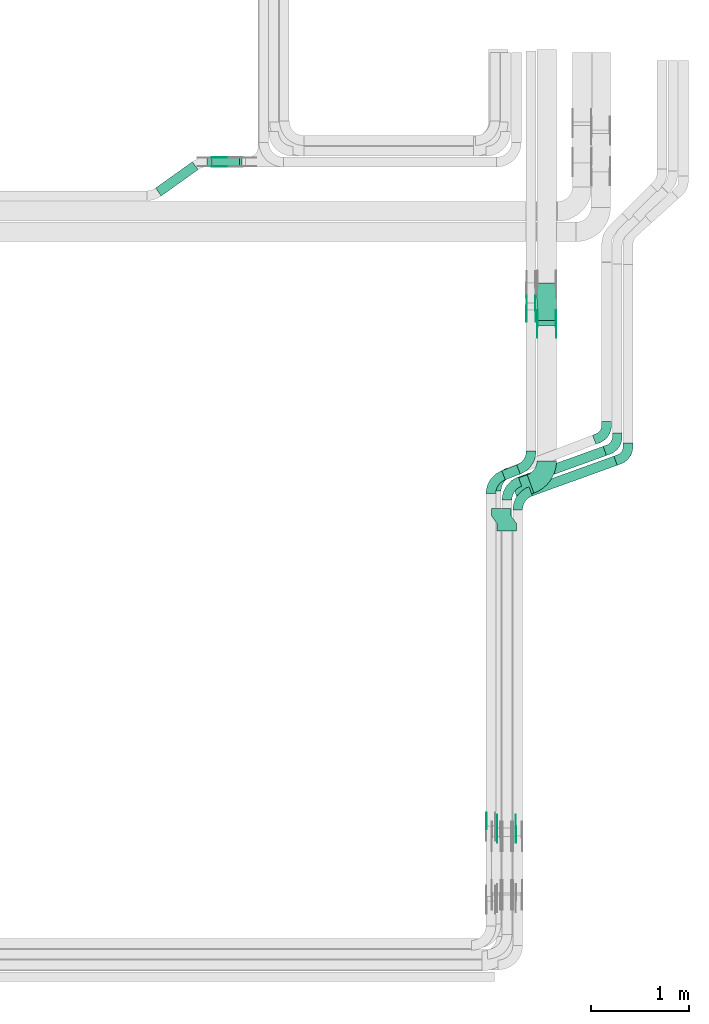
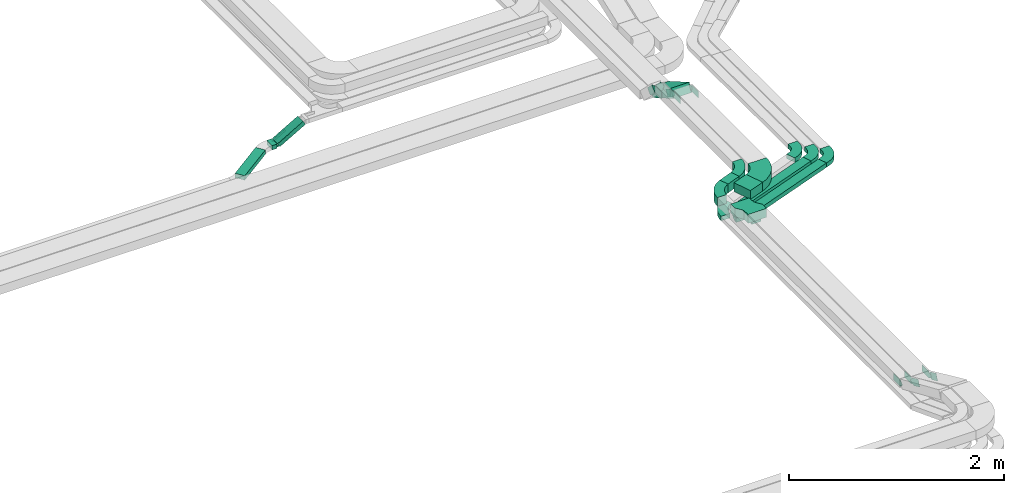
# One storey, part 19 of 23: 25 flow fittings, 8 flow segments.
"""IFC2X3 building model written with IfcOpenShell, lengths in millimetres."""

from ifc_helpers import new_model, entity, si_unit, converted_unit, derived_unit, direction, frame, frame_2d, origin, origin_2d_with_axis, place, context, subcontext, project, spatial, polyline, circle_curve, parameter, trimmed, segment, composite_curve, rectangle, outline, extrude, source, transform, mapped, material, type_object, type_shapes, element, save


model = new_model("IFC2X3")

# Units and contexts
model_context = context("Model", 3, precision=0.01, world=origin(), true_north=direction((6.12303176911189e-17, 1.0)))
body_context = subcontext(model_context, "Body", "Model", "MODEL_VIEW")
ifc_project = project(units=[si_unit("LENGTHUNIT", "METRE", prefix="MILLI"), si_unit("AREAUNIT", "SQUARE_METRE"), si_unit("VOLUMEUNIT", "CUBIC_METRE"), converted_unit("PLANEANGLEUNIT", "DEGREE", entity("IfcRatioMeasure", 0.0174532925199433), si_unit("PLANEANGLEUNIT", "RADIAN"), dimensions=[0, 0, 0, 0, 0, 0, 0]), si_unit("MASSUNIT", "GRAM", prefix="KILO"), derived_unit("MASSDENSITYUNIT", [(si_unit("MASSUNIT", "GRAM", prefix="KILO"), 1), (si_unit("LENGTHUNIT", "METRE"), -3)]), derived_unit("MOMENTOFINERTIAUNIT", [(si_unit("LENGTHUNIT", "METRE"), 4)]), si_unit("TIMEUNIT", "SECOND"), si_unit("FREQUENCYUNIT", "HERTZ"), si_unit("THERMODYNAMICTEMPERATUREUNIT", "DEGREE_CELSIUS"), derived_unit("THERMALTRANSMITTANCEUNIT", [(si_unit("MASSUNIT", "GRAM", prefix="KILO"), 1), (si_unit("THERMODYNAMICTEMPERATUREUNIT", "KELVIN"), -1), (si_unit("TIMEUNIT", "SECOND"), -3)]), derived_unit("VOLUMETRICFLOWRATEUNIT", [(si_unit("LENGTHUNIT", "METRE"), 3), (si_unit("TIMEUNIT", "SECOND"), -1)]), derived_unit("MASSFLOWRATEUNIT", [(si_unit("MASSUNIT", "GRAM", prefix="KILO"), 1), (si_unit("TIMEUNIT", "SECOND"), -1)]), derived_unit("ROTATIONALFREQUENCYUNIT", [(si_unit("TIMEUNIT", "SECOND"), -1)]), si_unit("ELECTRICCURRENTUNIT", "AMPERE"), si_unit("ELECTRICVOLTAGEUNIT", "VOLT"), si_unit("POWERUNIT", "WATT"), si_unit("FORCEUNIT", "NEWTON", prefix="KILO"), si_unit("ILLUMINANCEUNIT", "LUX"), si_unit("LUMINOUSFLUXUNIT", "LUMEN"), si_unit("LUMINOUSINTENSITYUNIT", "CANDELA"), derived_unit("USERDEFINED", [(si_unit("MASSUNIT", "GRAM", prefix="KILO"), -1), (si_unit("LENGTHUNIT", "METRE"), -2), (si_unit("TIMEUNIT", "SECOND"), 3), (si_unit("LUMINOUSFLUXUNIT", "LUMEN"), 1)]), derived_unit("LINEARVELOCITYUNIT", [(si_unit("LENGTHUNIT", "METRE"), 1), (si_unit("TIMEUNIT", "SECOND"), -1)]), si_unit("PRESSUREUNIT", "PASCAL"), derived_unit("USERDEFINED", [(si_unit("LENGTHUNIT", "METRE"), -2), (si_unit("MASSUNIT", "GRAM", prefix="KILO"), 1), (si_unit("TIMEUNIT", "SECOND"), -2)]), derived_unit("LINEARFORCEUNIT", [(si_unit("MASSUNIT", "GRAM", prefix="KILO"), 1), (si_unit("LENGTHUNIT", "METRE"), 1), (si_unit("TIMEUNIT", "SECOND"), -2), (si_unit("LENGTHUNIT", "METRE"), -1)]), derived_unit("PLANARFORCEUNIT", [(si_unit("MASSUNIT", "GRAM", prefix="KILO"), 1), (si_unit("LENGTHUNIT", "METRE"), 1), (si_unit("TIMEUNIT", "SECOND"), -2), (si_unit("LENGTHUNIT", "METRE"), -2)])], contexts=[model_context])

# Site, building, storey
site_placement = place(None, origin())
site = spatial("IfcSite", under=ifc_project, at=site_placement, CompositionType="ELEMENT")
building_placement = place(site_placement, origin())
building = spatial("IfcBuilding", under=site, at=building_placement, CompositionType="ELEMENT")
storey_placement = place(building_placement, frame((0.0, 0.0, 24000.0)))
storey = spatial("IfcBuildingStorey", under=building, at=storey_placement, CompositionType="ELEMENT", Elevation=24000.0)

# Flow segments
cable_carrier_segment_type = type_object("IfcCableCarrierSegmentType", PredefinedType="CABLETRAYSEGMENT")
flow_segment_1_placement = place(storey_placement, frame((64385.57, 9500.0, 2805.0)))
element("IfcFlowSegment", 1, at=flow_segment_1_placement, inside=storey, type_object=cable_carrier_segment_type, context=body_context, shape_type="SweptSolid", body=[
    extrude(rectangle(XDim=54.6374214492034, YDim=99.9999999999989, at=origin_2d_with_axis()), frame((27.32, 50.0, 0.0)), (0.0, 0.0, 1.0), 49.9999999999973),
])
flow_segment_2_placement = place(storey_placement, frame((64444.07, 9500.0, 2812.72)))
element("IfcFlowSegment", 2, at=flow_segment_2_placement, inside=storey, type_object=cable_carrier_segment_type, context=body_context, shape_type="SweptSolid", body=[
    extrude(rectangle(XDim=49.9999999999914, YDim=100.000000000001, at=origin_2d_with_axis()), frame((12.49, 50.0, 21.66), z_axis=(0.866342460674002, 0.0, 0.49945043881582), x_axis=(-0.49945043881582, 0.0, 0.866342460674002)), (0.0, 0.0, 1.0), 318.501540799204),
])
flow_segment_3_placement = place(storey_placement, frame((63861.37, 9202.14, 2805.0)))
element("IfcFlowSegment", 3, at=flow_segment_3_placement, inside=storey, type_object=cable_carrier_segment_type, context=body_context, shape_type="SweptSolid", body=[
    extrude(rectangle(XDim=463.396528175245, YDim=100.000000000006, at=origin_2d_with_axis()), frame((217.6, 175.36, 0.0), z_axis=(0.0, 0.0, 1.0), x_axis=(-0.813735449455938, -0.581235424160247, 0.0)), (0.0, 0.0, 1.0), 49.9999999999973),
])
flow_segment_4_placement = place(storey_placement, frame((67685.49, 6131.45, 2990.08)))
element("IfcFlowSegment", 4, at=flow_segment_4_placement, inside=storey, type_object=cable_carrier_segment_type, context=body_context, shape_type="SweptSolid", body=[
    extrude(rectangle(XDim=923.103409840237, YDim=99.9999999999998, at=origin_2d_with_axis()), frame((451.08, 203.87, 0.0), z_axis=(0.0, 0.0, 1.0), x_axis=(-0.940490250433855, -0.339820671588509, 0.0)), (0.0, 0.0, 1.0), 49.9999999999973),
])
flow_segment_5_placement = place(storey_placement, frame((67575.49, 6231.45, 2990.08)))
element("IfcFlowSegment", 5, at=flow_segment_5_placement, inside=storey, type_object=cable_carrier_segment_type, context=body_context, shape_type="SweptSolid", body=[
    extrude(rectangle(XDim=923.103392304729, YDim=99.9999999999998, at=origin_2d_with_axis()), frame((451.08, 203.87, 0.0), z_axis=(0.0, 0.0, 1.0), x_axis=(-0.940490250433858, -0.339820671588499, 0.0)), (0.0, 0.0, 1.0), 49.9999999999973),
])
flow_segment_6_placement = place(storey_placement, frame((67499.98, 6100.08, 3190.89)))
element("IfcFlowSegment", 6, at=flow_segment_6_placement, inside=storey, type_object=cable_carrier_segment_type, context=body_context, shape_type="SweptSolid", body=[
    extrude(rectangle(XDim=176.925883841124, YDim=200.000000000006, at=origin_2d_with_axis()), frame((117.18, 124.11, 0.0), z_axis=(0.0, 0.0, 1.0), x_axis=(-0.940490250433895, -0.339820671588397, 0.0)), (0.0, 0.0, 1.0), 100.000000000003),
])
flow_segment_7_placement = place(storey_placement, frame((67406.4, 6296.19, 3190.89)))
element("IfcFlowSegment", 7, at=flow_segment_7_placement, inside=storey, type_object=cable_carrier_segment_type, context=body_context, shape_type="SweptSolid", body=[
    extrude(rectangle(XDim=163.689208604183, YDim=99.9999999999947, at=origin_2d_with_axis()), frame((94.33, 76.02, 0.0), z_axis=(0.0, 0.0, 1.0), x_axis=(-0.933496460328319, -0.358586612347002, 0.0)), (0.0, 0.0, 1.0), 100.000000000003),
])
flow_segment_8_placement = place(storey_placement, frame((67766.35, 7878.57, 2969.7)))
element("IfcFlowSegment", 8, at=flow_segment_8_placement, inside=storey, type_object=cable_carrier_segment_type, context=body_context, shape_type="SweptSolid", body=[
    extrude(rectangle(XDim=99.9999999999966, YDim=440.304692414863, at=frame_2d((0.0, 0.0), x_axis=(0.0, 1.0))), frame((0.0, 215.66, 153.38), z_axis=(1.0, 0.0, 0.0), x_axis=(0.0, -0.866025403784429, 0.500000000000017)), (0.0, 0.0, 1.0), 200.000000000006),
])

# Flow fittings
ifc_material_1 = material()
cable_carrier_fitting_type_1 = type_object("IfcCableCarrierFittingType", PredefinedType="NOTDEFINED", material=ifc_material_1)
shared_shape_1 = source(origin(), body_context, "Body", "SweptSolid", [
    extrude(outline(polyline([(-115.0, -127.06), (-38.33, -127.06), (38.33, -72.94), (115.0, -72.94), (115.0, 127.06), (38.33, 127.06), (-38.33, 72.94), (-115.0, 72.94), (-115.0, -127.06)])), frame((115.0, 27.06, -50.0)), (0.0, 0.0, 1.0), 100.0),
])
type_shapes(cable_carrier_fitting_type_1, [shared_shape_1])
flow_fitting_1_placement = place(storey_placement, frame((67455.11, 5774.69, 3240.89), z_axis=(0.0, 0.0, 1.0), x_axis=(0.0, 1.0, 0.0)))
element("IfcFlowFitting", 9, at=flow_fitting_1_placement, inside=storey, type_object=cable_carrier_fitting_type_1, material=ifc_material_1, Name="470_DKC_S5_adapter", context=body_context, shape_type="MappedRepresentation", body=[
    mapped(shared_shape_1, transform((0.0, 0.0, 0.0), scale=1.0)),
])
ifc_material_2 = material(Name="G")
cable_carrier_fitting_type_2 = type_object("IfcCableCarrierFittingType", PredefinedType="NOTDEFINED", material=ifc_material_2)
shared_shape_2 = source(origin(), body_context, "Body", "SweptSolid", [
    extrude(outline(composite_curve([segment(trimmed(circle_curve(frame_2d((-44.59, 0.0), x_axis=(1.0, 0.0)), 12.5), [parameter(90.0000000000007)], [parameter(270.0)], True, "PARAMETER"), True, "CONTINUOUS"), segment(polyline([(-44.59, -12.5), (-33.09, -12.5)]), True, "CONTINUOUS"), segment(polyline([(-33.09, -12.5), (-31.23, -14.5)]), True, "CONTINUOUS"), segment(polyline([(-31.23, -14.5), (108.91, -14.5)]), True, "CONTINUOUS"), segment(polyline([(108.91, -14.5), (108.91, 14.5)]), True, "CONTINUOUS"), segment(polyline([(108.91, 14.5), (-31.23, 14.5)]), True, "CONTINUOUS"), segment(polyline([(-31.23, 14.5), (-33.09, 12.5)]), True, "CONTINUOUS"), segment(polyline([(-33.09, 12.5), (-44.59, 12.5)]), True, "CONTINUOUS")], self_intersect=False)), frame((44.59, 0.0, 0.0), z_axis=(0.0, 0.0, -1.0), x_axis=(1.0, 0.0, 0.0)), (0.0, 0.0, -1.0), 2.0),
])
type_shapes(cable_carrier_fitting_type_2, [shared_shape_2])
flow_fitting_2_placement = place(storey_placement, frame((64448.97, 9504.54, 2830.0), z_axis=(0.0, -1.0, 0.0), x_axis=(0.866342460673953, 0.0, 0.499450438815904)))
element("IfcFlowFitting", 10, at=flow_fitting_2_placement, inside=storey, type_object=cable_carrier_fitting_type_2, material=ifc_material_2, context=body_context, shape_type="MappedRepresentation", body=[
    mapped(shared_shape_2, transform((0.0, 0.0, 0.0), scale=1.0)),
])
cable_carrier_fitting_type_3 = type_object("IfcCableCarrierFittingType", PredefinedType="NOTDEFINED", material=ifc_material_2)
shared_shape_3 = source(origin(), body_context, "Body", "SweptSolid", [
    extrude(outline(composite_curve([segment(trimmed(circle_curve(frame_2d((-44.59, 0.0), x_axis=(1.0, 0.0)), 12.5), [parameter(90.0000000000007)], [parameter(270.0)], True, "PARAMETER"), True, "CONTINUOUS"), segment(polyline([(-44.59, -12.5), (-33.09, -12.5)]), True, "CONTINUOUS"), segment(polyline([(-33.09, -12.5), (-31.23, -14.5)]), True, "CONTINUOUS"), segment(polyline([(-31.23, -14.5), (108.91, -14.5)]), True, "CONTINUOUS"), segment(polyline([(108.91, -14.5), (108.91, 14.5)]), True, "CONTINUOUS"), segment(polyline([(108.91, 14.5), (-31.23, 14.5)]), True, "CONTINUOUS"), segment(polyline([(-31.23, 14.5), (-33.09, 12.5)]), True, "CONTINUOUS"), segment(polyline([(-33.09, 12.5), (-44.59, 12.5)]), True, "CONTINUOUS")], self_intersect=False)), frame((44.59, 0.0, 0.0)), (0.0, 0.0, 1.0), 2.0),
])
type_shapes(cable_carrier_fitting_type_3, [shared_shape_3])
flow_fitting_3_placement = place(storey_placement, frame((64448.97, 9595.46, 2830.0), z_axis=(0.0, 1.0, 0.0), x_axis=(0.866342460673953, 0.0, 0.499450438815904)))
element("IfcFlowFitting", 11, at=flow_fitting_3_placement, inside=storey, type_object=cable_carrier_fitting_type_3, material=ifc_material_2, context=body_context, shape_type="MappedRepresentation", body=[
    mapped(shared_shape_3, transform((0.0, 0.0, 0.0), scale=1.0)),
])
cable_carrier_fitting_type_4 = type_object("IfcCableCarrierFittingType", PredefinedType="NOTDEFINED", material=ifc_material_2)
shared_shape_4 = source(origin(), body_context, "Body", "SweptSolid", [
    extrude(outline(composite_curve([segment(trimmed(circle_curve(frame_2d((-41.47, 0.0), x_axis=(1.0, 0.0)), 25.0), [parameter(90.0000000000007)], [parameter(270.0)], True, "PARAMETER"), True, "CONTINUOUS"), segment(polyline([(-41.47, -25.0), (-29.97, -25.0)]), True, "CONTINUOUS"), segment(polyline([(-29.97, -25.0), (-28.1, -38.5)]), True, "CONTINUOUS"), segment(polyline([(-28.1, -38.5), (99.53, -38.5)]), True, "CONTINUOUS"), segment(polyline([(99.53, -38.5), (99.53, 38.5)]), True, "CONTINUOUS"), segment(polyline([(99.53, 38.5), (-28.1, 38.5)]), True, "CONTINUOUS"), segment(polyline([(-28.1, 38.5), (-29.97, 25.0)]), True, "CONTINUOUS"), segment(polyline([(-29.97, 25.0), (-41.47, 25.0)]), True, "CONTINUOUS")], self_intersect=False)), frame((41.47, 0.0, 0.0), z_axis=(0.0, 0.0, -1.0), x_axis=(1.0, 0.0, 0.0)), (0.0, 0.0, -1.0), 2.0),
])
type_shapes(cable_carrier_fitting_type_4, [shared_shape_4])
flow_fitting_4_placement = place(storey_placement, frame((67359.65, 2723.71, 3240.89), z_axis=(-1.0, 0.0, 0.0), x_axis=(0.0, -0.909506231619165, 0.415690286927545)))
element("IfcFlowFitting", 12, at=flow_fitting_4_placement, inside=storey, type_object=cable_carrier_fitting_type_4, material=ifc_material_2, context=body_context, shape_type="MappedRepresentation", body=[
    mapped(shared_shape_4, transform((0.0, 0.0, 0.0), scale=1.0)),
])
cable_carrier_fitting_type_5 = type_object("IfcCableCarrierFittingType", PredefinedType="NOTDEFINED", material=ifc_material_2)
type_shapes(cable_carrier_fitting_type_5, [shared_shape_4])
flow_fitting_5_placement = place(storey_placement, frame((67548.57, 2723.71, 3240.89), z_axis=(1.0, 0.0, 0.0), x_axis=(0.0, 1.0, 0.0)))
element("IfcFlowFitting", 13, at=flow_fitting_5_placement, inside=storey, type_object=cable_carrier_fitting_type_5, material=ifc_material_2, context=body_context, shape_type="MappedRepresentation", body=[
    mapped(shared_shape_4, transform((0.0, 0.0, 0.0), scale=1.0)),
])
flow_fitting_6_placement = place(storey_placement, frame((67961.81, 7890.17, 3240.89), z_axis=(1.0, 0.0, 0.0), x_axis=(0.0, -1.0, 0.0)))
element("IfcFlowFitting", 14, at=flow_fitting_6_placement, inside=storey, type_object=cable_carrier_fitting_type_4, material=ifc_material_2, context=body_context, shape_type="MappedRepresentation", body=[
    mapped(shared_shape_4, transform((0.0, 0.0, 0.0), scale=1.0)),
])
flow_fitting_7_placement = place(storey_placement, frame((67772.89, 7890.17, 3240.89), z_axis=(-1.0, 0.0, 0.0), x_axis=(0.0, 0.866025403784416, -0.50000000000004)))
element("IfcFlowFitting", 15, at=flow_fitting_7_placement, inside=storey, type_object=cable_carrier_fitting_type_5, material=ifc_material_2, context=body_context, shape_type="MappedRepresentation", body=[
    mapped(shared_shape_4, transform((0.0, 0.0, 0.0), scale=1.0)),
])
flow_fitting_8_placement = place(storey_placement, frame((67751.81, 8053.31, 3240.89), z_axis=(1.0, 0.0, 0.0), x_axis=(0.0, -1.0, 0.0)))
element("IfcFlowFitting", 16, at=flow_fitting_8_placement, inside=storey, type_object=cable_carrier_fitting_type_4, material=ifc_material_2, context=body_context, shape_type="MappedRepresentation", body=[
    mapped(shared_shape_4, transform((0.0, 0.0, 0.0), scale=1.0)),
])
flow_fitting_9_placement = place(storey_placement, frame((67662.89, 8053.31, 3240.89), z_axis=(-1.0, 0.0, 0.0), x_axis=(0.0, 0.707106781186515, -0.70710678118658)))
element("IfcFlowFitting", 17, at=flow_fitting_9_placement, inside=storey, type_object=cable_carrier_fitting_type_5, material=ifc_material_2, context=body_context, shape_type="MappedRepresentation", body=[
    mapped(shared_shape_4, transform((0.0, 0.0, 0.0), scale=1.0)),
])
cable_carrier_fitting_type_6 = type_object("IfcCableCarrierFittingType", PredefinedType="NOTDEFINED", material=ifc_material_2)
shared_shape_5 = source(origin(), body_context, "Body", "SweptSolid", [
    extrude(outline(composite_curve([segment(trimmed(circle_curve(frame_2d((-41.47, 0.0), x_axis=(1.0, 0.0)), 25.0), [parameter(90.0000000000007)], [parameter(270.0)], True, "PARAMETER"), True, "CONTINUOUS"), segment(polyline([(-41.47, -25.0), (-29.97, -25.0)]), True, "CONTINUOUS"), segment(polyline([(-29.97, -25.0), (-28.1, -38.5)]), True, "CONTINUOUS"), segment(polyline([(-28.1, -38.5), (99.53, -38.5)]), True, "CONTINUOUS"), segment(polyline([(99.53, -38.5), (99.53, 38.5)]), True, "CONTINUOUS"), segment(polyline([(99.53, 38.5), (-28.1, 38.5)]), True, "CONTINUOUS"), segment(polyline([(-28.1, 38.5), (-29.97, 25.0)]), True, "CONTINUOUS"), segment(polyline([(-29.97, 25.0), (-41.47, 25.0)]), True, "CONTINUOUS")], self_intersect=False)), frame((41.47, 0.0, 0.0)), (0.0, 0.0, 1.0), 2.0),
])
type_shapes(cable_carrier_fitting_type_6, [shared_shape_5])
flow_fitting_10_placement = place(storey_placement, frame((67251.65, 2745.06, 3240.89), z_axis=(-1.0, 0.0, 0.0), x_axis=(0.0, 1.0, 0.0)))
element("IfcFlowFitting", 18, at=flow_fitting_10_placement, inside=storey, type_object=cable_carrier_fitting_type_6, material=ifc_material_2, context=body_context, shape_type="MappedRepresentation", body=[
    mapped(shared_shape_5, transform((0.0, 0.0, 0.0), scale=1.0)),
])
cable_carrier_fitting_type_7 = type_object("IfcCableCarrierFittingType", PredefinedType="NOTDEFINED", material=ifc_material_2)
type_shapes(cable_carrier_fitting_type_7, [shared_shape_5])
flow_fitting_11_placement = place(storey_placement, frame((67550.57, 2723.71, 3240.89), z_axis=(1.0, 0.0, 0.0), x_axis=(0.0, -0.909506231619165, 0.415690286927545)))
element("IfcFlowFitting", 19, at=flow_fitting_11_placement, inside=storey, type_object=cable_carrier_fitting_type_7, material=ifc_material_2, context=body_context, shape_type="MappedRepresentation", body=[
    mapped(shared_shape_5, transform((0.0, 0.0, 0.0), scale=1.0)),
])
flow_fitting_12_placement = place(storey_placement, frame((67361.65, 2723.71, 3240.89), z_axis=(-1.0, 0.0, 0.0), x_axis=(0.0, 1.0, 0.0)))
element("IfcFlowFitting", 20, at=flow_fitting_12_placement, inside=storey, type_object=cable_carrier_fitting_type_6, material=ifc_material_2, context=body_context, shape_type="MappedRepresentation", body=[
    mapped(shared_shape_5, transform((0.0, 0.0, 0.0), scale=1.0)),
])
flow_fitting_13_placement = place(storey_placement, frame((67770.89, 7890.17, 3240.89), z_axis=(-1.0, 0.0, 0.0), x_axis=(0.0, -1.0, 0.0)))
element("IfcFlowFitting", 21, at=flow_fitting_13_placement, inside=storey, type_object=cable_carrier_fitting_type_7, material=ifc_material_2, context=body_context, shape_type="MappedRepresentation", body=[
    mapped(shared_shape_5, transform((0.0, 0.0, 0.0), scale=1.0)),
])
flow_fitting_14_placement = place(storey_placement, frame((67959.81, 7890.17, 3240.89), z_axis=(1.0, 0.0, 0.0), x_axis=(0.0, 0.866025403784416, -0.50000000000004)))
element("IfcFlowFitting", 22, at=flow_fitting_14_placement, inside=storey, type_object=cable_carrier_fitting_type_6, material=ifc_material_2, context=body_context, shape_type="MappedRepresentation", body=[
    mapped(shared_shape_5, transform((0.0, 0.0, 0.0), scale=1.0)),
])
flow_fitting_15_placement = place(storey_placement, frame((67660.89, 8053.31, 3240.89), z_axis=(-1.0, 0.0, 0.0), x_axis=(0.0, -1.0, 0.0)))
element("IfcFlowFitting", 23, at=flow_fitting_15_placement, inside=storey, type_object=cable_carrier_fitting_type_7, material=ifc_material_2, context=body_context, shape_type="MappedRepresentation", body=[
    mapped(shared_shape_5, transform((0.0, 0.0, 0.0), scale=1.0)),
])
flow_fitting_16_placement = place(storey_placement, frame((67749.81, 8053.31, 3240.89), z_axis=(1.0, 0.0, 0.0), x_axis=(0.0, 0.707106781186515, -0.70710678118658)))
element("IfcFlowFitting", 24, at=flow_fitting_16_placement, inside=storey, type_object=cable_carrier_fitting_type_6, material=ifc_material_2, context=body_context, shape_type="MappedRepresentation", body=[
    mapped(shared_shape_5, transform((0.0, 0.0, 0.0), scale=1.0)),
])
cable_carrier_fitting_type_8 = type_object("IfcCableCarrierFittingType", Name="470_DKC_S5_Variable Angle Elbow 0-45:-", PredefinedType="NOTDEFINED", material=ifc_material_1)
shared_shape_6 = source(origin(), body_context, "Body", "SweptSolid", [
    extrude(outline(composite_curve([segment(polyline([(-94.88, -116.25), (-93.88, -116.25)]), True, "CONTINUOUS"), segment(trimmed(circle_curve(frame_2d((-93.88, 133.75), x_axis=(0.0, -1.0)), 250.0), [parameter(0.0)], [parameter(70.1340512054867)], True, "PARAMETER"), True, "CONTINUOUS"), segment(polyline([(141.24, 48.79), (141.58, 49.73)]), True, "CONTINUOUS"), segment(polyline([(141.58, 49.73), (47.53, 83.71)]), True, "CONTINUOUS"), segment(polyline([(47.53, 83.71), (47.19, 82.77)]), True, "CONTINUOUS"), segment(trimmed(circle_curve(frame_2d((-93.88, 133.75), x_axis=(0.0, -1.0)), 150.0), [parameter(0.0)], [parameter(70.1340512054867)], True, "PARAMETER"), False, "CONTINUOUS"), segment(polyline([(-93.88, -16.25), (-94.88, -16.25)]), True, "CONTINUOUS"), segment(polyline([(-94.88, -16.25), (-94.88, -116.25)]), True, "CONTINUOUS")], self_intersect=False)), frame((-46.51, 66.25, -25.0)), (0.0, 0.0, 1.0), 49.9999999999998),
])
type_shapes(cable_carrier_fitting_type_8, [shared_shape_6])
for number, where, z_axis, x_axis, name in (
    (25, (67569.5, 6130.42, 3015.08), (0.0, 0.0, 1.0), (-0.940490250433852, -0.339820671588517, 0.0), "470_DKC_S5_Variable Angle Elbow 0-45:-"),
    (26, (67459.5, 6230.42, 3015.08), (0.0, 0.0, 1.0), (-0.940490250433858, -0.339820671588499, 0.0), "470_DKC_S5_Variable Angle Elbow 0-45:-"),
):
    element("IfcFlowFitting", number, at=place(storey_placement, frame(where, z_axis=z_axis, x_axis=x_axis)), inside=storey, type_object=cable_carrier_fitting_type_8, material=ifc_material_1, Name=name, ObjectType="470_DKC_S5_Variable Angle Elbow 0-45:-", context=body_context, shape_type="MappedRepresentation", body=[
        mapped(shared_shape_6, transform((0.0, 0.0, 0.0), scale=1.0)),
    ])
cable_carrier_fitting_type_9 = type_object("IfcCableCarrierFittingType", Name="470_DKC_S5_Variable Angle Elbow 0-45:-", PredefinedType="NOTDEFINED", material=ifc_material_1)
shared_shape_7 = source(origin(), body_context, "Body", "SweptSolid", [
    extrude(outline(composite_curve([segment(polyline([(-94.19, -114.37), (-93.19, -114.37)]), True, "CONTINUOUS"), segment(trimmed(circle_curve(frame_2d((-93.19, 135.63), x_axis=(0.0, -1.0)), 250.0), [parameter(0.0)], [parameter(68.9865796039687)], True, "PARAMETER"), True, "CONTINUOUS"), segment(polyline([(140.18, 45.98), (140.54, 46.91)]), True, "CONTINUOUS"), segment(polyline([(140.54, 46.91), (47.19, 82.77)]), True, "CONTINUOUS"), segment(polyline([(47.19, 82.77), (46.84, 81.84)]), True, "CONTINUOUS"), segment(trimmed(circle_curve(frame_2d((-93.19, 135.63), x_axis=(0.0, -1.0)), 150.0), [parameter(0.0)], [parameter(68.9865796039687)], True, "PARAMETER"), False, "CONTINUOUS"), segment(polyline([(-93.19, -14.37), (-94.19, -14.37)]), True, "CONTINUOUS"), segment(polyline([(-94.19, -14.37), (-94.19, -114.37)]), True, "CONTINUOUS")], self_intersect=False)), frame((-44.23, 64.37, -25.0)), (0.0, 0.0, 1.0), 49.9999999999998),
])
type_shapes(cable_carrier_fitting_type_9, [shared_shape_7])
flow_fitting_17_placement = place(storey_placement, frame((67349.5, 6322.22, 3015.08), z_axis=(0.0, 0.0, 1.0), x_axis=(-0.933496460328297, -0.358586612347061, 0.0)))
element("IfcFlowFitting", 27, at=flow_fitting_17_placement, inside=storey, type_object=cable_carrier_fitting_type_9, material=ifc_material_1, Name="470_DKC_S5_Variable Angle Elbow 0-45:-", ObjectType="470_DKC_S5_Variable Angle Elbow 0-45:-", context=body_context, shape_type="MappedRepresentation", body=[
    mapped(shared_shape_7, transform((0.0, 0.0, 0.0), scale=1.0)),
])
cable_carrier_fitting_type_10 = type_object("IfcCableCarrierFittingType", Name="470_DKC_S5_Variable Angle Elbow 0-45:-", PredefinedType="NOTDEFINED", material=ifc_material_1)
shared_shape_8 = source(origin(), body_context, "Body", "SweptSolid", [
    extrude(outline(composite_curve([segment(polyline([(-94.19, -114.37), (-93.19, -114.37)]), True, "CONTINUOUS"), segment(trimmed(circle_curve(frame_2d((-93.19, 135.63), x_axis=(0.0, -1.0)), 250.0), [parameter(0.0)], [parameter(68.98657960397)], True, "PARAMETER"), True, "CONTINUOUS"), segment(polyline([(140.18, 45.98), (140.54, 46.91)]), True, "CONTINUOUS"), segment(polyline([(140.54, 46.91), (47.19, 82.77)]), True, "CONTINUOUS"), segment(polyline([(47.19, 82.77), (46.84, 81.84)]), True, "CONTINUOUS"), segment(trimmed(circle_curve(frame_2d((-93.19, 135.63), x_axis=(0.0, -1.0)), 150.0), [parameter(0.0)], [parameter(68.98657960397)], True, "PARAMETER"), False, "CONTINUOUS"), segment(polyline([(-93.19, -14.37), (-94.19, -14.37)]), True, "CONTINUOUS"), segment(polyline([(-94.19, -14.37), (-94.19, -114.37)]), True, "CONTINUOUS")], self_intersect=False)), frame((-44.23, 64.37, -50.0)), (0.0, 0.0, 1.0), 100.0),
])
type_shapes(cable_carrier_fitting_type_10, [shared_shape_8])
for number, where, z_axis, x_axis, name in (
    (28, (67295.11, 6293.22, 3240.89), (0.0, 0.0, 1.0), (-0.933496460328307, -0.358586612347034, 0.0), "470_DKC_S5_Variable Angle Elbow 0-45:-"),
    (29, (67706.35, 6451.19, 3240.89), (0.0, 0.0, 1.0), (0.933496460328325, 0.358586612346986, 0.0), "470_DKC_S5_Variable Angle Elbow 0-45:-"),
):
    element("IfcFlowFitting", number, at=place(storey_placement, frame(where, z_axis=z_axis, x_axis=x_axis)), inside=storey, type_object=cable_carrier_fitting_type_10, material=ifc_material_1, Name=name, ObjectType="470_DKC_S5_Variable Angle Elbow 0-45:-", context=body_context, shape_type="MappedRepresentation", body=[
        mapped(shared_shape_8, transform((0.0, 0.0, 0.0), scale=1.0)),
    ])
cable_carrier_fitting_type_11 = type_object("IfcCableCarrierFittingType", Name="470_DKC_S5_Variable Angle Elbow 0-45:-", PredefinedType="NOTDEFINED", material=ifc_material_1)
shared_shape_9 = source(origin(), body_context, "Body", "SweptSolid", [
    extrude(outline(composite_curve([segment(polyline([(-118.4, -182.76), (-117.4, -182.76)]), True, "CONTINUOUS"), segment(trimmed(circle_curve(frame_2d((-117.4, 167.24), x_axis=(0.0, -1.0)), 350.0), [parameter(0.0)], [parameter(70.1340512054877)], True, "PARAMETER"), True, "CONTINUOUS"), segment(polyline([(211.78, 48.31), (212.12, 49.25)]), True, "CONTINUOUS"), segment(polyline([(212.12, 49.25), (24.02, 117.21)]), True, "CONTINUOUS"), segment(polyline([(24.02, 117.21), (23.68, 116.27)]), True, "CONTINUOUS"), segment(trimmed(circle_curve(frame_2d((-117.4, 167.24), x_axis=(0.0, -1.0)), 150.0), [parameter(0.0)], [parameter(70.1340512054877)], True, "PARAMETER"), False, "CONTINUOUS"), segment(polyline([(-117.4, 17.24), (-118.4, 17.24)]), True, "CONTINUOUS"), segment(polyline([(-118.4, 17.24), (-118.4, -182.76)]), True, "CONTINUOUS")], self_intersect=False)), frame((-58.09, 82.76, -50.0)), (0.0, 0.0, 1.0), 100.0),
])
type_shapes(cable_carrier_fitting_type_11, [shared_shape_9])
flow_fitting_18_placement = place(storey_placement, frame((67866.35, 6314.23, 3240.89), z_axis=(0.0, 0.0, 1.0), x_axis=(0.940490250434052, 0.339820671587962, 0.0)))
element("IfcFlowFitting", 30, at=flow_fitting_18_placement, inside=storey, type_object=cable_carrier_fitting_type_11, material=ifc_material_1, Name="470_DKC_S5_Variable Angle Elbow 0-45:-", ObjectType="470_DKC_S5_Variable Angle Elbow 0-45:-", context=body_context, shape_type="MappedRepresentation", body=[
    mapped(shared_shape_9, transform((0.0, 0.0, 0.0), scale=1.0)),
])
cable_carrier_fitting_type_12 = type_object("IfcCableCarrierFittingType", Name="470_DKC_S5_CD 90 external vertical angle:-", PredefinedType="NOTDEFINED", material=ifc_material_1)
shared_shape_10 = source(origin(), body_context, "Body", "SweptSolid", [
    extrude(outline(composite_curve([segment(polyline([(-97.88, -103.94), (-59.13, -103.94)]), True, "CONTINUOUS"), segment(trimmed(circle_curve(frame_2d((-59.13, 86.06), x_axis=(0.0, -1.0)), 189.999999999999), [parameter(0.0)], [parameter(68.9868643994459)], True, "PARAMETER"), True, "CONTINUOUS"), segment(polyline([(118.23, 17.93), (132.12, 54.09)]), True, "CONTINUOUS"), segment(polyline([(132.12, 54.09), (38.78, 89.95)]), True, "CONTINUOUS"), segment(polyline([(38.78, 89.95), (24.88, 53.79)]), True, "CONTINUOUS"), segment(trimmed(circle_curve(frame_2d((-59.13, 86.06), x_axis=(0.0, -1.0)), 89.9999999999988), [parameter(0.0)], [parameter(68.9868643994459)], True, "PARAMETER"), False, "CONTINUOUS"), segment(polyline([(-59.13, -3.94), (-97.88, -3.94)]), True, "CONTINUOUS"), segment(polyline([(-97.88, -3.94), (-97.88, -103.94)]), True, "CONTINUOUS")], self_intersect=False)), frame((-37.06, 53.94, -25.0)), (0.0, 0.0, 1.0), 49.9999999999999),
])
type_shapes(cable_carrier_fitting_type_12, [shared_shape_10])
flow_fitting_19_placement = place(storey_placement, frame((68479.09, 6756.13, 3015.05), z_axis=(-0.00195415449481352, 0.00508718463275336, 0.999985150806112), x_axis=(0.933496460328297, 0.358586612347061, 0.0)))
element("IfcFlowFitting", 31, at=flow_fitting_19_placement, inside=storey, type_object=cable_carrier_fitting_type_12, material=ifc_material_1, Name="470_DKC_S5_CD 90 external vertical angle:-", ObjectType="470_DKC_S5_CD 90 external vertical angle:-", context=body_context, shape_type="MappedRepresentation", body=[
    mapped(shared_shape_10, transform((0.0, 0.0, 0.0), scale=1.0)),
])
cable_carrier_fitting_type_13 = type_object("IfcCableCarrierFittingType", Name="470_DKC_S5_CD 90 external vertical angle:-", PredefinedType="NOTDEFINED", material=ifc_material_1)
shared_shape_11 = source(origin(), body_context, "Body", "SweptSolid", [
    extrude(outline(composite_curve([segment(polyline([(-97.81, -105.22), (-59.51, -105.22)]), True, "CONTINUOUS"), segment(trimmed(circle_curve(frame_2d((-59.51, 84.78), x_axis=(0.0, -1.0)), 189.999999999999), [parameter(0.0)], [parameter(70.1343044803136)], True, "PARAMETER"), True, "CONTINUOUS"), segment(polyline([(119.18, 20.22), (132.19, 56.23)]), True, "CONTINUOUS"), segment(polyline([(132.19, 56.23), (38.14, 90.21)]), True, "CONTINUOUS"), segment(polyline([(38.14, 90.21), (25.13, 54.2)]), True, "CONTINUOUS"), segment(trimmed(circle_curve(frame_2d((-59.51, 84.78), x_axis=(0.0, -1.0)), 89.9999999999988), [parameter(0.0)], [parameter(70.1343044803136)], True, "PARAMETER"), False, "CONTINUOUS"), segment(polyline([(-59.51, -5.22), (-97.81, -5.22)]), True, "CONTINUOUS"), segment(polyline([(-97.81, -5.22), (-97.81, -105.22)]), True, "CONTINUOUS")], self_intersect=False)), frame((-38.76, 55.22, -25.0)), (0.0, 0.0, 1.0), 49.9999999999999),
])
type_shapes(cable_carrier_fitting_type_13, [shared_shape_11])
flow_fitting_20_placement = place(storey_placement, frame((68589.09, 6638.57, 3015.08), z_axis=(-0.00178729233590968, 0.00494652373188675, 0.999986168648885), x_axis=(0.940490250433858, 0.339820671588499, 0.0)))
element("IfcFlowFitting", 32, at=flow_fitting_20_placement, inside=storey, type_object=cable_carrier_fitting_type_13, material=ifc_material_1, Name="470_DKC_S5_CD 90 external vertical angle:-", ObjectType="470_DKC_S5_CD 90 external vertical angle:-", context=body_context, shape_type="MappedRepresentation", body=[
    mapped(shared_shape_11, transform((0.0, 0.0, 0.0), scale=1.0)),
])
cable_carrier_fitting_type_14 = type_object("IfcCableCarrierFittingType", Name="470_DKC_S5_CD 90 external vertical angle:-", PredefinedType="NOTDEFINED", material=ifc_material_1)
shared_shape_12 = source(origin(), body_context, "Body", "SweptSolid", [
    extrude(outline(composite_curve([segment(polyline([(-97.81, -105.22), (-59.51, -105.22)]), True, "CONTINUOUS"), segment(trimmed(circle_curve(frame_2d((-59.51, 84.78), x_axis=(0.0, -1.0)), 189.999999999999), [parameter(0.0)], [parameter(70.1342924019919)], True, "PARAMETER"), True, "CONTINUOUS"), segment(polyline([(119.18, 20.22), (132.19, 56.23)]), True, "CONTINUOUS"), segment(polyline([(132.19, 56.23), (38.14, 90.21)]), True, "CONTINUOUS"), segment(polyline([(38.14, 90.21), (25.13, 54.2)]), True, "CONTINUOUS"), segment(trimmed(circle_curve(frame_2d((-59.51, 84.78), x_axis=(0.0, -1.0)), 89.9999999999988), [parameter(0.0)], [parameter(70.1342924019919)], True, "PARAMETER"), False, "CONTINUOUS"), segment(polyline([(-59.51, -5.22), (-97.81, -5.22)]), True, "CONTINUOUS"), segment(polyline([(-97.81, -5.22), (-97.81, -105.22)]), True, "CONTINUOUS")], self_intersect=False)), frame((-38.76, 55.22, -25.0)), (0.0, 0.0, 1.0), 49.9999999999999),
])
type_shapes(cable_carrier_fitting_type_14, [shared_shape_12])
flow_fitting_21_placement = place(storey_placement, frame((68699.09, 6538.57, 3015.08), z_axis=(-0.00174415538806387, 0.00482713759009349, 0.999986828245587), x_axis=(0.940490250433852, 0.339820671588517, 0.0)))
element("IfcFlowFitting", 33, at=flow_fitting_21_placement, inside=storey, type_object=cable_carrier_fitting_type_14, material=ifc_material_1, Name="470_DKC_S5_CD 90 external vertical angle:-", ObjectType="470_DKC_S5_CD 90 external vertical angle:-", context=body_context, shape_type="MappedRepresentation", body=[
    mapped(shared_shape_12, transform((0.0, 0.0, 0.0), scale=1.0)),
])

save(model, "model.ifc")
